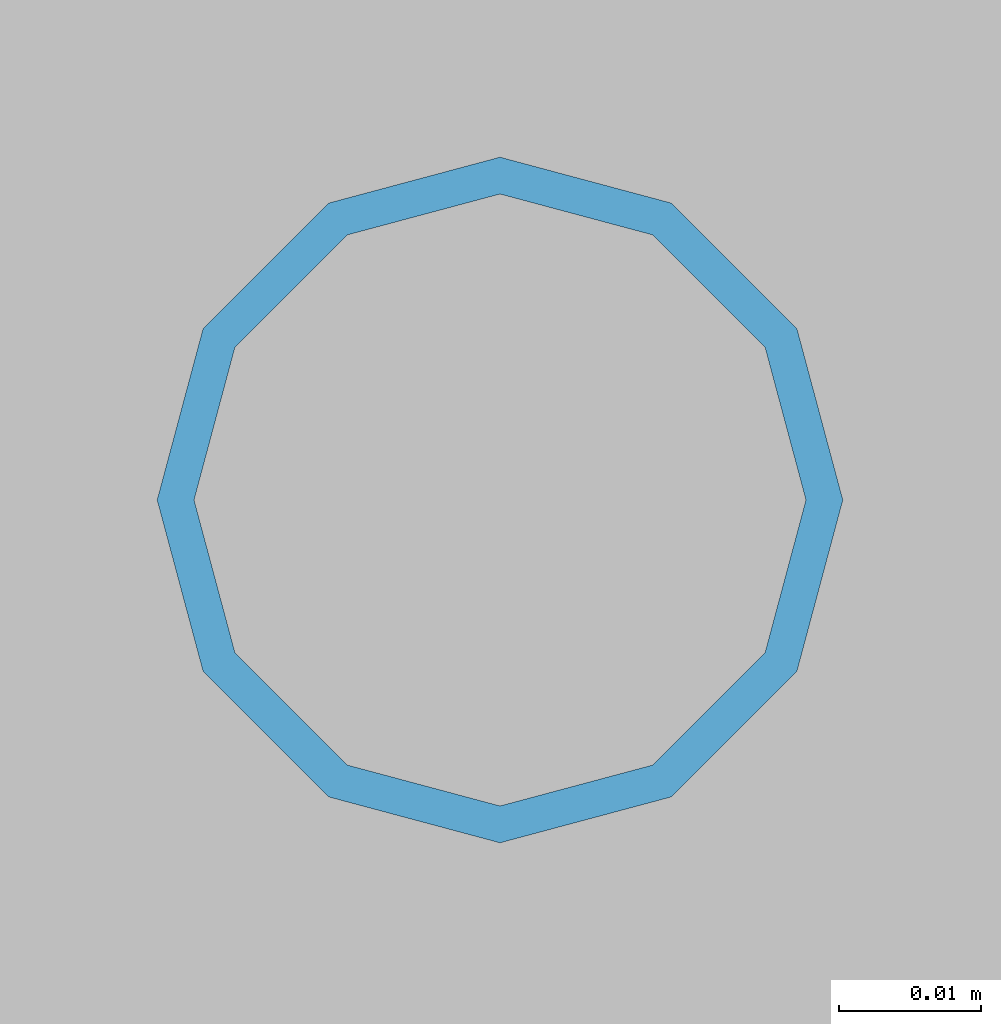
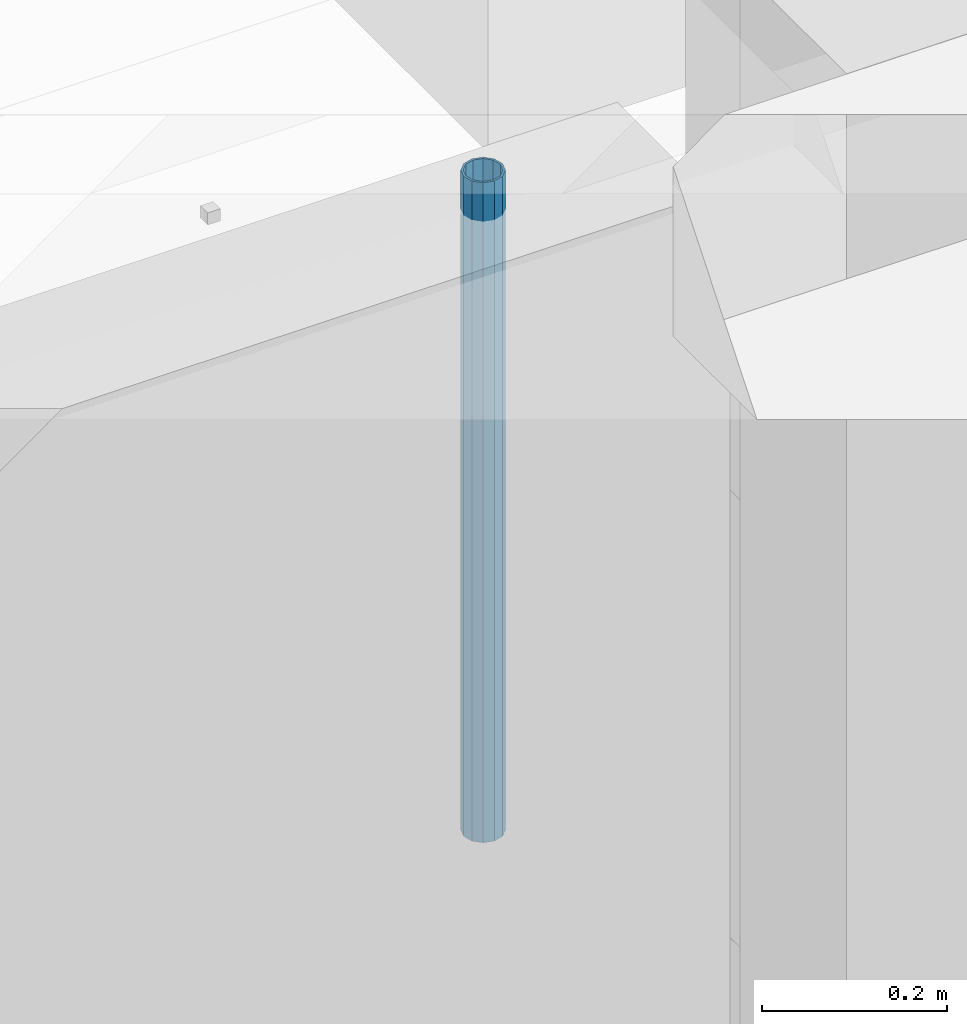
# One storey, part 22 of 309: 1 column, 1 element without a shape of its own.
"""IFC2X3 building model written with IfcOpenShell, lengths in millimetres."""

from ifc_helpers import new_model, si_unit, frame, origin_with_axes, place, context, subcontext, project, spatial, faceted_brep, material, type_object, element, aggregate, save


model = new_model("IFC2X3")

# Units and contexts
model_context = context("Model", 3, precision=1e-05, world=origin_with_axes())
body_context = subcontext(model_context, "Body", "Model", "MODEL_VIEW")
ifc_project = project(units=[si_unit("LENGTHUNIT", "METRE", prefix="MILLI"), si_unit("AREAUNIT", "SQUARE_METRE"), si_unit("VOLUMEUNIT", "CUBIC_METRE"), si_unit("MASSUNIT", "GRAM", prefix="KILO"), si_unit("TIMEUNIT", "SECOND"), si_unit("PLANEANGLEUNIT", "RADIAN"), si_unit("SOLIDANGLEUNIT", "STERADIAN"), si_unit("THERMODYNAMICTEMPERATUREUNIT", "DEGREE_CELSIUS"), si_unit("LUMINOUSINTENSITYUNIT", "LUMEN")], contexts=[model_context])

# Site, building, storey
site_placement = place(None, origin_with_axes())
site = spatial("IfcSite", under=ifc_project, at=site_placement, CompositionType="ELEMENT")
building_placement = place(site_placement, origin_with_axes())
building = spatial("IfcBuilding", under=site, at=building_placement, CompositionType="ELEMENT")
storey_placement = place(building_placement, origin_with_axes())
storey = spatial("IfcBuildingStorey", under=building, at=storey_placement, Name="7", CompositionType="ELEMENT", Elevation=0.0)

# Assembly, column
assembly_placement = place(storey_placement, origin_with_axes())
assembly = element("IfcElementAssembly", 1, at=assembly_placement, inside=storey, AssemblyPlace="NOTDEFINED", PredefinedType="REINFORCEMENT_UNIT")
ifc_material = material()
column_type = type_object("IfcColumnType", Name="48.3X2.6", PredefinedType="NOTDEFINED")
column_placement = place(assembly_placement, frame((14250.0, 16980.0, 101650.0), z_axis=(-1.0, 3.00000001838171e-08, 0.0), x_axis=(0.0, 0.0, 1.0)))
column = element("IfcColumn", 2, at=column_placement, type_object=column_type, material=ifc_material, ObjectType="48.3X2.6", context=body_context, shape_type="Brep", body=[
    faceted_brep([(0.0, -21.5499999999993, 0.0), (0.0, -18.6628474515564, 10.7750000000015), (870.0, -18.6628474515564, 10.7750000000015), (870.0, -21.5499999999993, 0.0), (0.0, -10.7750000000015, 18.6628474515564), (870.0, -10.7750000000015, 18.6628474515564), (0.0, 0.0, 21.5499999999993), (870.0, 0.0, 21.5499999999993), (0.0, 10.7750000000015, 18.6628474515564), (870.0, 10.7750000000015, 18.6628474515564), (0.0, 18.6628474515564, 10.7750000000015), (870.0, 18.6628474515564, 10.7750000000015), (0.0, 21.5499999999993, 0.0), (870.0, 21.5499999999993, 0.0), (0.0, 18.6628474515564, -10.7750000000015), (870.0, 18.6628474515564, -10.7750000000015), (0.0, 10.7750000000015, -18.6628474515564), (870.0, 10.7750000000015, -18.6628474515564), (0.0, 0.0, -21.5499999999993), (870.0, 0.0, -21.5499999999993), (0.0, -10.7750000000015, -18.6628474515564), (870.0, -10.7750000000015, -18.6628474515564), (0.0, -18.6628474515564, -10.7750000000015), (870.0, -18.6628474515564, -10.7750000000015), (0.0, -24.1500000000015, 0.0), (0.0, -20.9145135013932, -12.0750000000007), (870.0, -20.9145135013932, -12.0750000000007), (870.0, -24.1500000000015, 0.0), (0.0, -12.0750000000007, -20.9145135013932), (870.0, -12.0750000000007, -20.9145135013932), (0.0, 0.0, -24.1500000000015), (870.0, 0.0, -24.1500000000015), (0.0, 12.0750000000007, -20.9145135013932), (870.0, 12.0750000000007, -20.9145135013932), (0.0, 20.9145135013932, -12.0750000000007), (870.0, 20.9145135013932, -12.0750000000007), (0.0, 24.1500000000015, 0.0), (870.0, 24.1500000000015, 0.0), (0.0, 20.9145135013932, 12.0750000000007), (870.0, 20.9145135013932, 12.0750000000007), (0.0, 12.0750000000007, 20.9145135013932), (870.0, 12.0750000000007, 20.9145135013932), (0.0, 0.0, 24.1500000000015), (870.0, 0.0, 24.1500000000015), (0.0, -12.0750000000007, 20.9145135013932), (870.0, -12.0750000000007, 20.9145135013932), (0.0, -20.9145135013932, 12.0750000000007), (870.0, -20.9145135013932, 12.0750000000007)], [[[0, 1, 2, 3]], [[1, 4, 5, 2]], [[4, 6, 7, 5]], [[6, 8, 9, 7]], [[8, 10, 11, 9]], [[10, 12, 13, 11]], [[12, 14, 15, 13]], [[14, 16, 17, 15]], [[16, 18, 19, 17]], [[18, 20, 21, 19]], [[20, 22, 23, 21]], [[22, 0, 3, 23]], [[24, 25, 26, 27]], [[25, 28, 29, 26]], [[28, 30, 31, 29]], [[30, 32, 33, 31]], [[32, 34, 35, 33]], [[34, 36, 37, 35]], [[36, 38, 39, 37]], [[38, 40, 41, 39]], [[40, 42, 43, 41]], [[42, 44, 45, 43]], [[44, 46, 47, 45]], [[46, 24, 27, 47]], [[29, 31, 33, 35, 37, 39, 41, 43, 45, 47, 27, 26], [5, 7, 9, 11, 13, 15, 17, 19, 21, 23, 3, 2]], [[46, 44, 42, 40, 38, 36, 34, 32, 30, 28, 25, 24], [22, 20, 18, 16, 14, 12, 10, 8, 6, 4, 1, 0]]]),
])
aggregate(assembly, [column])

save(model, "model.ifc")
